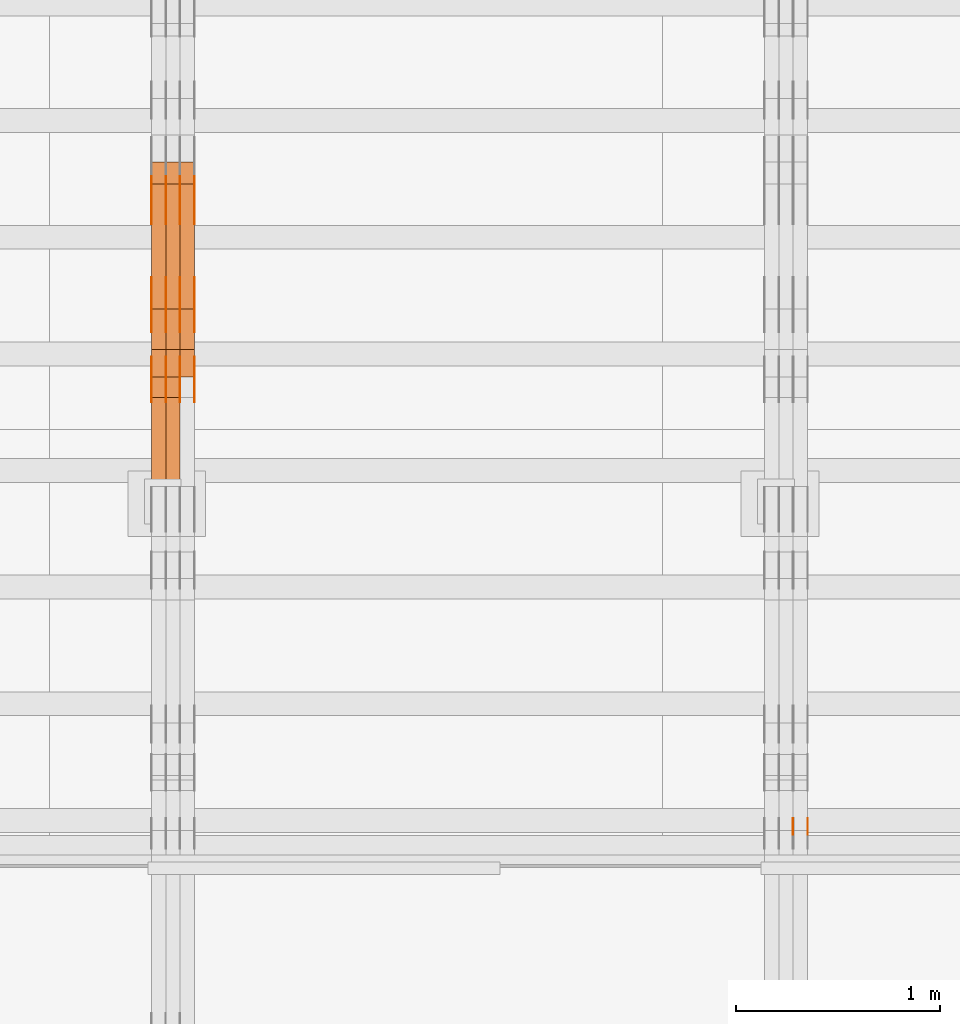
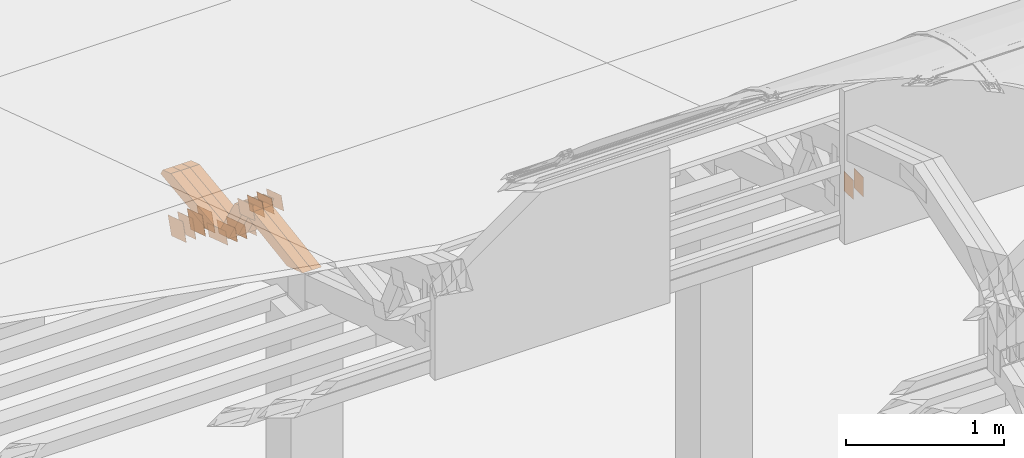
# One storey, part 149 of 385: 28 proxies.
"""IFC2X3 building model written with IfcOpenShell, lengths in millimetres."""

import ifcopenshell
import ifcopenshell.guid

model = None  # the IFC model being written
_history = None  # IfcOwnerHistory: only IFC2X3 demands one
_inside = {}  # id of a spatial element -> (the spatial element, [elements in it])
_under = {}  # id of a project, library or spatial element -> (it, [spatial elements below it])
_declared = {}  # id of a project -> (the project, [libraries it declares])
_typed = {}  # id of a type object -> (the type object, [elements of that type])
_made_of = {}  # id of a material, layer set ... -> (it, [elements and type objects made of it])


def new_model(schema):
    """Start an empty IFC model of exactly this schema.

    Asked for "IFC4X3", IfcOpenShell would pick the latest addendum, in which some entities
    have other attributes; the version numbers below select the first issue.
    IFC2X3 requires an IfcOwnerHistory on every rooted entity: one is made here for all.
    """
    global model, _history
    if schema == "IFC4X3":
        model = ifcopenshell.file(schema_version=(4, 3, 0, 0))
    else:
        model = ifcopenshell.file(schema=schema)
    _inside.clear()
    _under.clear()
    _declared.clear()
    _typed.clear()
    _made_of.clear()
    _history = None
    if model.schema == "IFC2X3":
        org = make("IfcOrganization", Name="unknown")
        user = make(
            "IfcPersonAndOrganization",
            ThePerson=make("IfcPerson", FamilyName="unknown"),
            TheOrganization=org,
        )
        app = make(
            "IfcApplication",
            ApplicationDeveloper=org,
            Version="unknown",
            ApplicationFullName="unknown",
            ApplicationIdentifier="unknown",
        )
        _history = make(
            "IfcOwnerHistory",
            OwningUser=user,
            OwningApplication=app,
            ChangeAction="ADDED",
            CreationDate=0,
        )
    return model


def make(cls, **values):
    """One entity of the class cls with the attributes given. An attribute that is None is left unset."""
    return model.create_entity(
        cls, **{name: value for name, value in values.items() if value is not None}
    )


def entity(cls, *values):
    """Any entity or typed value of the class cls, its attributes in the order of the schema. None: left unset."""
    e = model.create_entity(cls)
    for i, value in enumerate(values):
        if value is not None:
            e[i] = value
    return e


def rooted(cls, **values):
    """An entity with a GlobalId (a new one), such as an element, a storey or a relation."""
    return make(cls, GlobalId=ifcopenshell.guid.new(), OwnerHistory=_history, **values)


def si_unit(unit_type, name, prefix=None):
    """IfcSIUnit, for example si_unit("LENGTHUNIT", "METRE", prefix="MILLI")."""
    return make("IfcSIUnit", UnitType=unit_type, Prefix=prefix, Name=name)


def converted_unit(unit_type, name, factor, base, dimensions=None, offset=None):
    """IfcConversionBasedUnit, such as the inch: factor (a typed value) times the base unit."""
    return make(
        "IfcConversionBasedUnit"
        if offset is None
        else "IfcConversionBasedUnitWithOffset",
        ConversionOffset=offset,
        Dimensions=None
        if dimensions is None
        else entity("IfcDimensionalExponents", *dimensions),
        UnitType=unit_type,
        Name=name,
        ConversionFactor=make(
            "IfcMeasureWithUnit", ValueComponent=factor, UnitComponent=base
        ),
    )


def derived_unit(unit_type, elements):
    """IfcDerivedUnit: a product of units, each with its exponent."""
    return make(
        "IfcDerivedUnit",
        Elements=[
            make("IfcDerivedUnitElement", Unit=unit, Exponent=power)
            for unit, power in elements
        ],
        UnitType=unit_type,
    )


def assignment(units):
    """IfcUnitAssignment: the units of a project."""
    return None if units is None else make("IfcUnitAssignment", Units=units)


def point(xyz):
    """IfcCartesianPoint."""
    return None if xyz is None else make("IfcCartesianPoint", Coordinates=xyz)


def direction(xyz):
    """IfcDirection."""
    return None if xyz is None else make("IfcDirection", DirectionRatios=xyz)


def frame(location, z_axis=None, x_axis=None):
    """IfcAxis2Placement3D, a coordinate frame: its origin and axes. An axis left out is left unset."""
    return make(
        "IfcAxis2Placement3D",
        Location=point(location),
        Axis=direction(z_axis),
        RefDirection=direction(x_axis),
    )


def frame_2d(location, x_axis=None):
    """IfcAxis2Placement2D, a coordinate frame in the plane: its origin and x axis."""
    return make(
        "IfcAxis2Placement2D", Location=point(location), RefDirection=direction(x_axis)
    )


def origin():
    """The frame at (0, 0, 0) with its axes left unset."""
    return frame((0.0, 0.0, 0.0))


def origin_2d_with_axis():
    """The frame at (0, 0) in the plane with the x axis (1, 0) written out."""
    return frame_2d((0.0, 0.0), x_axis=(1.0, 0.0))


def place(relative_to, where):
    """IfcLocalPlacement: puts the frame where relative to a parent placement (None: the world)."""
    return make(
        "IfcLocalPlacement", PlacementRelTo=relative_to, RelativePlacement=where
    )


def context(
    kind, dimensions, precision=None, world=None, true_north=None, identifier=None
):
    """IfcGeometricRepresentationContext, for example the 3D "Model" context."""
    return make(
        "IfcGeometricRepresentationContext",
        ContextIdentifier=identifier,
        ContextType=kind,
        CoordinateSpaceDimension=dimensions,
        Precision=precision,
        WorldCoordinateSystem=world,
        TrueNorth=true_north,
    )


def subcontext(parent, identifier, kind, view, scale=None):
    """IfcGeometricRepresentationSubContext, for example "Body" below "Model"."""
    return make(
        "IfcGeometricRepresentationSubContext",
        ContextIdentifier=identifier,
        ContextType=kind,
        ParentContext=parent,
        TargetScale=scale,
        TargetView=view,
    )


def project(units=None, contexts=None):
    """IfcProject with its units and contexts."""
    return rooted(
        "IfcProject",
        Name="project",
        RepresentationContexts=contexts,
        UnitsInContext=assignment(units),
    )


def spatial(cls, under=None, at=None, **own):
    """A site, building, storey or space (cls), placed at a placement, below another one or the project."""
    s = rooted(cls, ObjectPlacement=at, **own)
    if under is not None:
        _under.setdefault(under.id(), (under, []))[1].append(s)
    return s


def polyline(points):
    """IfcPolyline through the points."""
    return make("IfcPolyline", Points=[point(p) for p in points])


def profile(cls, at=None, kind="AREA", **sizes):
    """A parametric profile (cls). Its sizes go by their IFC names, for example OverallWidth=200.0."""
    return make(cls, ProfileType=kind, Position=at, **sizes)


def rectangle(**sizes):
    """IfcRectangleProfileDef."""
    return profile("IfcRectangleProfileDef", **sizes)


def outline(outer, holes=None, kind="AREA"):
    """IfcArbitraryClosedProfileDef: a profile drawn as a closed curve; with holes, ...WithVoids."""
    if holes is None:
        return make("IfcArbitraryClosedProfileDef", ProfileType=kind, OuterCurve=outer)
    return make(
        "IfcArbitraryProfileDefWithVoids",
        ProfileType=kind,
        OuterCurve=outer,
        InnerCurves=holes,
    )


def extrude(swept, where, along, depth):
    """IfcExtrudedAreaSolid: the profile swept, set in the frame where, extruded along a direction by depth."""
    return make(
        "IfcExtrudedAreaSolid",
        SweptArea=swept,
        Position=where,
        ExtrudedDirection=direction(along),
        Depth=depth,
    )


def shape(context_of_items, identifier, shape_type, items):
    """IfcShapeRepresentation: the items that make up one representation, for example the "Body"."""
    return make(
        "IfcShapeRepresentation",
        ContextOfItems=context_of_items,
        RepresentationIdentifier=identifier,
        RepresentationType=shape_type,
        Items=items,
    )


def source(mapping_origin, context_of_items, identifier, shape_type, items):
    """IfcRepresentationMap: a shape defined once, which mapped items show again and again."""
    return make(
        "IfcRepresentationMap",
        MappingOrigin=mapping_origin,
        MappedRepresentation=shape(context_of_items, identifier, shape_type, items),
    )


def transform(
    local_origin,
    x_axis=None,
    y_axis=None,
    z_axis=None,
    scale=None,
    scale2=None,
    scale3=None,
    uniform=True,
):
    """IfcCartesianTransformationOperator3D, or its non-uniform kind. x_axis, y_axis, z_axis: its Axis1, 2, 3."""
    if uniform:
        return make(
            "IfcCartesianTransformationOperator3D",
            Axis1=direction(x_axis),
            Axis2=direction(y_axis),
            LocalOrigin=point(local_origin),
            Scale=scale,
            Axis3=direction(z_axis),
        )
    return make(
        "IfcCartesianTransformationOperator3DnonUniform",
        Axis1=direction(x_axis),
        Axis2=direction(y_axis),
        LocalOrigin=point(local_origin),
        Scale=scale,
        Axis3=direction(z_axis),
        Scale2=scale2,
        Scale3=scale3,
    )


def mapped(mapping_source, mapping_target):
    """IfcMappedItem: shows the shape of a source again, moved by a transform."""
    return make(
        "IfcMappedItem", MappingSource=mapping_source, MappingTarget=mapping_target
    )


def material(Name=None, Category=None):
    """IfcMaterial."""
    return make("IfcMaterial", Name=Name, Category=Category)


def made_of(thing, what):
    """Note that an element or type object is made of a material, layer set ...; save() writes the relation."""
    if what is not None:
        _made_of.setdefault(what.id(), (what, []))[1].append(thing)
    return thing


def type_object(cls, material=None, **own):
    """A type object (cls), such as IfcWallType, which elements share."""
    return made_of(rooted(cls, **own), material)


def type_shapes(of_type, sources):
    """Give a type object the sources (RepresentationMaps) that its elements show as mapped items."""
    of_type.RepresentationMaps = sources


def element(
    cls,
    number,
    at=None,
    inside=None,
    cuts=None,
    type_object=None,
    material=None,
    context=None,
    identifier="Body",
    shape_type=None,
    held_by="IfcProductDefinitionShape",
    body=None,
    shapes=None,
    **own,
):
    """One element of the class cls, such as IfcWall. Its Tag is "e" and its number.

    at: its placement. inside: the storey or other place that contains it. cuts: it is an
    opening in that element (IfcRelVoidsElement). A single representation is given by context,
    identifier, shape_type and body (its items); several are given by shapes. held_by: the class
    of the entity that holds the representations. save() writes the other relations.
    """
    e = rooted(cls, Tag="e%d" % number, ObjectPlacement=at, **own)
    if body is not None:
        shapes = [shape(context, identifier, shape_type, body)]
    if shapes is not None:
        e.Representation = make(held_by, Representations=shapes)
    if inside is not None:
        _inside.setdefault(inside.id(), (inside, []))[1].append(e)
    if cuts is not None:
        rooted(
            "IfcRelVoidsElement", RelatingBuildingElement=cuts, RelatedOpeningElement=e
        )
    if type_object is not None:
        _typed.setdefault(type_object.id(), (type_object, []))[1].append(e)
    return made_of(e, material)


def aggregate(whole, parts):
    """IfcRelAggregates: a whole, such as a stair, and the parts it consists of."""
    return rooted("IfcRelAggregates", RelatingObject=whole, RelatedObjects=parts)


def save(model, path):
    """Write the relations noted so far, then the file.

    IfcRelAggregates (storeys below a building ...), IfcRelContainedInSpatialStructure (elements
    in a storey), IfcRelDefinesByType, IfcRelAssociatesMaterial and IfcRelDeclares: one each for
    every whole, place, type object, material and project.
    """
    for whole, parts in _under.values():
        aggregate(whole, parts)
    for where, things in _inside.values():
        rooted(
            "IfcRelContainedInSpatialStructure",
            RelatedElements=things,
            RelatingStructure=where,
        )
    for kind, things in _typed.values():
        rooted("IfcRelDefinesByType", RelatedObjects=things, RelatingType=kind)
    for what, things in _made_of.values():
        rooted("IfcRelAssociatesMaterial", RelatedObjects=things, RelatingMaterial=what)
    for by, libraries in _declared.values():
        rooted("IfcRelDeclares", RelatingContext=by, RelatedDefinitions=libraries)
    model.write(path)


model = new_model("IFC2X3")

# Units and contexts
model_context = context("Model", 3, precision=0.01, world=origin(), true_north=direction((6.12303176911189e-17, 1.0)))
body_context = subcontext(model_context, "Body", "Model", "MODEL_VIEW")
ifc_project = project(units=[si_unit("LENGTHUNIT", "METRE", prefix="MILLI"), si_unit("AREAUNIT", "SQUARE_METRE"), si_unit("VOLUMEUNIT", "CUBIC_METRE"), converted_unit("PLANEANGLEUNIT", "DEGREE", entity("IfcRatioMeasure", 0.0174532925199433), si_unit("PLANEANGLEUNIT", "RADIAN"), dimensions=[0, 0, 0, 0, 0, 0, 0]), si_unit("MASSUNIT", "GRAM", prefix="KILO"), derived_unit("MASSDENSITYUNIT", [(si_unit("MASSUNIT", "GRAM", prefix="KILO"), 1), (si_unit("LENGTHUNIT", "METRE"), -3)]), si_unit("TIMEUNIT", "SECOND"), si_unit("FREQUENCYUNIT", "HERTZ"), si_unit("THERMODYNAMICTEMPERATUREUNIT", "DEGREE_CELSIUS"), derived_unit("THERMALTRANSMITTANCEUNIT", [(si_unit("MASSUNIT", "GRAM", prefix="KILO"), 1), (si_unit("THERMODYNAMICTEMPERATUREUNIT", "KELVIN"), -1), (si_unit("TIMEUNIT", "SECOND"), -3)]), derived_unit("VOLUMETRICFLOWRATEUNIT", [(si_unit("LENGTHUNIT", "METRE"), 3), (si_unit("TIMEUNIT", "SECOND"), -1)]), si_unit("ELECTRICCURRENTUNIT", "AMPERE"), si_unit("ELECTRICVOLTAGEUNIT", "VOLT"), si_unit("POWERUNIT", "WATT"), si_unit("FORCEUNIT", "NEWTON", prefix="KILO"), si_unit("ILLUMINANCEUNIT", "LUX"), si_unit("LUMINOUSFLUXUNIT", "LUMEN"), si_unit("LUMINOUSINTENSITYUNIT", "CANDELA"), derived_unit("USERDEFINED", [(si_unit("MASSUNIT", "GRAM", prefix="KILO"), -1), (si_unit("LENGTHUNIT", "METRE"), -2), (si_unit("TIMEUNIT", "SECOND"), 3), (si_unit("LUMINOUSFLUXUNIT", "LUMEN"), 1)]), derived_unit("LINEARVELOCITYUNIT", [(si_unit("LENGTHUNIT", "METRE"), 1), (si_unit("TIMEUNIT", "SECOND"), -1)]), si_unit("PRESSUREUNIT", "PASCAL"), derived_unit("USERDEFINED", [(si_unit("LENGTHUNIT", "METRE"), -2), (si_unit("MASSUNIT", "GRAM", prefix="KILO"), 1), (si_unit("TIMEUNIT", "SECOND"), -2)])], contexts=[model_context])

# Site, building, storey
site_placement = place(None, origin())
site = spatial("IfcSite", under=ifc_project, at=site_placement, CompositionType="ELEMENT")
building_placement = place(site_placement, origin())
building = spatial("IfcBuilding", under=site, at=building_placement, CompositionType="ELEMENT")
storey_placement = place(building_placement, origin())
storey = spatial("IfcBuildingStorey", under=building, at=storey_placement, Name="Default", CompositionType="ELEMENT", Elevation=0.0)

# Proxies
ifc_material_1 = material(Name="IfcSurfaceStyle #274242")
building_element_proxy_type_1 = type_object("IfcBuildingElementProxyType", PredefinedType="NOTDEFINED", material=ifc_material_1)
shared_shape_1 = source(origin(), body_context, "Body", "SweptSolid", [
    extrude(rectangle(XDim=150.0, YDim=120.0, at=origin_2d_with_axis()), frame((75.0, 60.0, 0.0), z_axis=(0.0, 0.0, 1.0), x_axis=(-1.0, 0.0, 0.0)), (0.0, 0.0, 1.0), 1.3),
])
type_shapes(building_element_proxy_type_1, [shared_shape_1])
proxy_1_placement = place(building_placement, frame((21386.3, 15840.0, 3652.70166015625), z_axis=(-1.0, 0.0, 0.0), x_axis=(0.0, 0.0, -1.0)))
element("IfcBuildingElementProxy", 1, at=proxy_1_placement, inside=storey, type_object=building_element_proxy_type_1, material=ifc_material_1, context=body_context, shape_type="MappedRepresentation", body=[
    mapped(shared_shape_1, transform((0.0, 0.0, 0.0), scale=1.0)),
])
ifc_material_2 = material(Name="IfcSurfaceStyle #274185")
building_element_proxy_type_2 = type_object("IfcBuildingElementProxyType", PredefinedType="NOTDEFINED", material=ifc_material_2)
shared_shape_2 = source(origin(), body_context, "Body", "SweptSolid", [
    extrude(rectangle(XDim=150.0, YDim=120.0, at=origin_2d_with_axis()), frame((75.0, 60.0, 0.0), z_axis=(0.0, 0.0, 1.0), x_axis=(-1.0, 0.0, 0.0)), (0.0, 0.0, 1.0), 1.3),
])
type_shapes(building_element_proxy_type_2, [shared_shape_2])
proxy_2_placement = place(building_placement, frame((21315.0, 15840.0, 3652.70166015625), z_axis=(-1.0, 0.0, 0.0), x_axis=(0.0, 0.0, -1.0)))
element("IfcBuildingElementProxy", 2, at=proxy_2_placement, inside=storey, type_object=building_element_proxy_type_2, material=ifc_material_2, context=body_context, shape_type="MappedRepresentation", body=[
    mapped(shared_shape_2, transform((0.0, 0.0, 0.0), scale=1.0)),
])
ifc_material_3 = material(Name="IfcSurfaceStyle #239126")
building_element_proxy_type_3 = type_object("IfcBuildingElementProxyType", PredefinedType="NOTDEFINED", material=ifc_material_3)
shared_shape_3 = source(origin(), body_context, "Body", "SweptSolid", [
    extrude(outline(polyline([(-125.00031378339, -47.9999612158856), (125.000225258022, -47.9999612158856), (124.999811678525, 47.9999612158856), (-124.999723153156, 47.9999612158856), (-125.00031378339, -47.9999612158856)])), frame((125.000225258022, 48.0000091013474, 0.0), z_axis=(0.0, 0.0, 1.0), x_axis=(-1.0, 0.0, 0.0)), (0.0, 0.0, 1.0), 1.3),
])
type_shapes(building_element_proxy_type_3, [shared_shape_3])
proxy_3_placement = place(building_placement, frame((18386.3, 18456.8597683375, 2657.46691321253), z_axis=(-1.0, 0.0, 0.0), x_axis=(0.0, -0.951056516295124, 0.309016994375039)))
element("IfcBuildingElementProxy", 3, at=proxy_3_placement, inside=storey, type_object=building_element_proxy_type_3, material=ifc_material_3, context=body_context, shape_type="MappedRepresentation", body=[
    mapped(shared_shape_3, transform((0.0, 0.0, 0.0), scale=1.0)),
])
ifc_material_4 = material(Name="IfcSurfaceStyle #239069")
building_element_proxy_type_4 = type_object("IfcBuildingElementProxyType", PredefinedType="NOTDEFINED", material=ifc_material_4)
shared_shape_4 = source(origin(), body_context, "Body", "SweptSolid", [
    extrude(outline(polyline([(-125.00031378339, -47.9999612158856), (125.000225258022, -47.9999612158856), (124.999811678525, 47.9999612158856), (-124.999723153156, 47.9999612158856), (-125.00031378339, -47.9999612158856)])), frame((125.000225258022, 48.0000091013474, 0.0), z_axis=(0.0, 0.0, 1.0), x_axis=(-1.0, 0.0, 0.0)), (0.0, 0.0, 1.0), 1.3),
])
type_shapes(building_element_proxy_type_4, [shared_shape_4])
proxy_4_placement = place(building_placement, frame((18315.0, 18456.8597683375, 2657.46691321253), z_axis=(-1.0, 0.0, 0.0), x_axis=(0.0, -0.951056516295124, 0.309016994375039)))
element("IfcBuildingElementProxy", 4, at=proxy_4_placement, inside=storey, type_object=building_element_proxy_type_4, material=ifc_material_4, context=body_context, shape_type="MappedRepresentation", body=[
    mapped(shared_shape_4, transform((0.0, 0.0, 0.0), scale=1.0)),
])
ifc_material_5 = material(Name="IfcSurfaceStyle #239012")
building_element_proxy_type_5 = type_object("IfcBuildingElementProxyType", PredefinedType="NOTDEFINED", material=ifc_material_5)
shared_shape_5 = source(origin(), body_context, "Body", "SweptSolid", [
    extrude(outline(polyline([(-125.00031378339, -47.9999612158856), (125.000225258022, -47.9999612158856), (124.999811678525, 47.9999612158856), (-124.999723153156, 47.9999612158856), (-125.00031378339, -47.9999612158856)])), frame((125.000225258022, 48.0000091013474, 0.0), z_axis=(0.0, 0.0, 1.0), x_axis=(-1.0, 0.0, 0.0)), (0.0, 0.0, 1.0), 1.3),
])
type_shapes(building_element_proxy_type_5, [shared_shape_5])
proxy_5_placement = place(building_placement, frame((18316.3, 18456.8597683375, 2657.46691321253), z_axis=(-1.0, 0.0, 0.0), x_axis=(0.0, -0.951056516295124, 0.309016994375039)))
element("IfcBuildingElementProxy", 5, at=proxy_5_placement, inside=storey, type_object=building_element_proxy_type_5, material=ifc_material_5, context=body_context, shape_type="MappedRepresentation", body=[
    mapped(shared_shape_5, transform((0.0, 0.0, 0.0), scale=1.0)),
])
ifc_material_6 = material(Name="IfcSurfaceStyle #238955")
building_element_proxy_type_6 = type_object("IfcBuildingElementProxyType", PredefinedType="NOTDEFINED", material=ifc_material_6)
shared_shape_6 = source(origin(), body_context, "Body", "SweptSolid", [
    extrude(outline(polyline([(-125.00031378339, -47.9999612158856), (125.000225258022, -47.9999612158856), (124.999811678525, 47.9999612158856), (-124.999723153156, 47.9999612158856), (-125.00031378339, -47.9999612158856)])), frame((125.000225258022, 48.0000091013474, 0.0), z_axis=(0.0, 0.0, 1.0), x_axis=(-1.0, 0.0, 0.0)), (0.0, 0.0, 1.0), 1.29999999999998),
])
type_shapes(building_element_proxy_type_6, [shared_shape_6])
proxy_6_placement = place(building_placement, frame((18245.0, 18456.8597683375, 2657.46691321253), z_axis=(-1.0, 0.0, 0.0), x_axis=(0.0, -0.951056516295124, 0.309016994375039)))
element("IfcBuildingElementProxy", 6, at=proxy_6_placement, inside=storey, type_object=building_element_proxy_type_6, material=ifc_material_6, context=body_context, shape_type="MappedRepresentation", body=[
    mapped(shared_shape_6, transform((0.0, 0.0, 0.0), scale=1.0)),
])
ifc_material_7 = material(Name="IfcSurfaceStyle #238898")
building_element_proxy_type_7 = type_object("IfcBuildingElementProxyType", PredefinedType="NOTDEFINED", material=ifc_material_7)
shared_shape_7 = source(origin(), body_context, "Body", "SweptSolid", [
    extrude(outline(polyline([(-125.00031378339, -47.9999612158856), (125.000225258022, -47.9999612158856), (124.999811678525, 47.9999612158856), (-124.999723153156, 47.9999612158856), (-125.00031378339, -47.9999612158856)])), frame((125.000225258022, 48.0000091013474, 0.0), z_axis=(0.0, 0.0, 1.0), x_axis=(-1.0, 0.0, 0.0)), (0.0, 0.0, 1.0), 1.29999999999998),
])
type_shapes(building_element_proxy_type_7, [shared_shape_7])
proxy_7_placement = place(building_placement, frame((18246.3, 18456.8597683375, 2657.46691321253), z_axis=(-1.0, 0.0, 0.0), x_axis=(0.0, -0.951056516295124, 0.309016994375039)))
element("IfcBuildingElementProxy", 7, at=proxy_7_placement, inside=storey, type_object=building_element_proxy_type_7, material=ifc_material_7, context=body_context, shape_type="MappedRepresentation", body=[
    mapped(shared_shape_7, transform((0.0, 0.0, 0.0), scale=1.0)),
])
ifc_material_8 = material(Name="IfcSurfaceStyle #238841")
building_element_proxy_type_8 = type_object("IfcBuildingElementProxyType", PredefinedType="NOTDEFINED", material=ifc_material_8)
shared_shape_8 = source(origin(), body_context, "Body", "SweptSolid", [
    extrude(outline(polyline([(-125.00031378339, -47.9999612158856), (125.000225258022, -47.9999612158856), (124.999811678525, 47.9999612158856), (-124.999723153156, 47.9999612158856), (-125.00031378339, -47.9999612158856)])), frame((125.000225258022, 48.0000091013474, 0.0), z_axis=(0.0, 0.0, 1.0), x_axis=(-1.0, 0.0, 0.0)), (0.0, 0.0, 1.0), 1.29999999999998),
])
type_shapes(building_element_proxy_type_8, [shared_shape_8])
proxy_8_placement = place(building_placement, frame((18175.0, 18456.8597683375, 2657.46691321253), z_axis=(-1.0, 0.0, 0.0), x_axis=(0.0, -0.951056516295124, 0.309016994375039)))
element("IfcBuildingElementProxy", 8, at=proxy_8_placement, inside=storey, type_object=building_element_proxy_type_8, material=ifc_material_8, context=body_context, shape_type="MappedRepresentation", body=[
    mapped(shared_shape_8, transform((0.0, 0.0, 0.0), scale=1.0)),
])
ifc_material_9 = material(Name="IfcSurfaceStyle #237416")
building_element_proxy_type_9 = type_object("IfcBuildingElementProxyType", PredefinedType="NOTDEFINED", material=ifc_material_9)
shared_shape_9 = source(origin(), body_context, "Body", "SweptSolid", [
    extrude(outline(polyline([(-99.999796294464, -72.0000050220467), (99.9998768370438, -72.0000050220467), (100.000260677528, 72.0000050220467), (-100.000341220108, 72.0000050220467), (-99.999796294464, -72.0000050220467)])), frame((100.000260677528, 72.0000050220467, 0.0), z_axis=(0.0, 0.0, 1.0), x_axis=(-1.0, 0.0, 0.0)), (0.0, 0.0, 1.0), 1.3),
])
type_shapes(building_element_proxy_type_9, [shared_shape_9])
proxy_9_placement = place(building_placement, frame((18386.3, 18936.3876569477, 2373.90613192527), z_axis=(-1.0, 0.0, 0.0), x_axis=(0.0, -0.951056516295124, 0.309016994375039)))
element("IfcBuildingElementProxy", 9, at=proxy_9_placement, inside=storey, type_object=building_element_proxy_type_9, material=ifc_material_9, context=body_context, shape_type="MappedRepresentation", body=[
    mapped(shared_shape_9, transform((0.0, 0.0, 0.0), scale=1.0)),
])
ifc_material_10 = material(Name="IfcSurfaceStyle #237359")
building_element_proxy_type_10 = type_object("IfcBuildingElementProxyType", PredefinedType="NOTDEFINED", material=ifc_material_10)
shared_shape_10 = source(origin(), body_context, "Body", "SweptSolid", [
    extrude(outline(polyline([(-99.999796294464, -72.0000050220467), (99.9998768370438, -72.0000050220467), (100.000260677528, 72.0000050220467), (-100.000341220108, 72.0000050220467), (-99.999796294464, -72.0000050220467)])), frame((100.000260677528, 72.0000050220467, 0.0), z_axis=(0.0, 0.0, 1.0), x_axis=(-1.0, 0.0, 0.0)), (0.0, 0.0, 1.0), 1.3),
])
type_shapes(building_element_proxy_type_10, [shared_shape_10])
proxy_10_placement = place(building_placement, frame((18315.0, 18936.3876569477, 2373.90613192527), z_axis=(-1.0, 0.0, 0.0), x_axis=(0.0, -0.951056516295124, 0.309016994375039)))
element("IfcBuildingElementProxy", 10, at=proxy_10_placement, inside=storey, type_object=building_element_proxy_type_10, material=ifc_material_10, context=body_context, shape_type="MappedRepresentation", body=[
    mapped(shared_shape_10, transform((0.0, 0.0, 0.0), scale=1.0)),
])
ifc_material_11 = material(Name="IfcSurfaceStyle #237302")
building_element_proxy_type_11 = type_object("IfcBuildingElementProxyType", PredefinedType="NOTDEFINED", material=ifc_material_11)
shared_shape_11 = source(origin(), body_context, "Body", "SweptSolid", [
    extrude(outline(polyline([(-99.999796294464, -72.0000050220467), (99.9998768370438, -72.0000050220467), (100.000260677528, 72.0000050220467), (-100.000341220108, 72.0000050220467), (-99.999796294464, -72.0000050220467)])), frame((100.000260677528, 72.0000050220467, 0.0), z_axis=(0.0, 0.0, 1.0), x_axis=(-1.0, 0.0, 0.0)), (0.0, 0.0, 1.0), 1.3),
])
type_shapes(building_element_proxy_type_11, [shared_shape_11])
proxy_11_placement = place(building_placement, frame((18316.3, 18936.3876569477, 2373.90613192527), z_axis=(-1.0, 0.0, 0.0), x_axis=(0.0, -0.951056516295124, 0.309016994375039)))
element("IfcBuildingElementProxy", 11, at=proxy_11_placement, inside=storey, type_object=building_element_proxy_type_11, material=ifc_material_11, context=body_context, shape_type="MappedRepresentation", body=[
    mapped(shared_shape_11, transform((0.0, 0.0, 0.0), scale=1.0)),
])
ifc_material_12 = material(Name="IfcSurfaceStyle #237245")
building_element_proxy_type_12 = type_object("IfcBuildingElementProxyType", PredefinedType="NOTDEFINED", material=ifc_material_12)
shared_shape_12 = source(origin(), body_context, "Body", "SweptSolid", [
    extrude(outline(polyline([(-99.999796294464, -72.0000050220467), (99.9998768370438, -72.0000050220467), (100.000260677528, 72.0000050220467), (-100.000341220108, 72.0000050220467), (-99.999796294464, -72.0000050220467)])), frame((100.000260677528, 72.0000050220467, 0.0), z_axis=(0.0, 0.0, 1.0), x_axis=(-1.0, 0.0, 0.0)), (0.0, 0.0, 1.0), 1.29999999999998),
])
type_shapes(building_element_proxy_type_12, [shared_shape_12])
proxy_12_placement = place(building_placement, frame((18245.0, 18936.3876569477, 2373.90613192527), z_axis=(-1.0, 0.0, 0.0), x_axis=(0.0, -0.951056516295124, 0.309016994375039)))
element("IfcBuildingElementProxy", 12, at=proxy_12_placement, inside=storey, type_object=building_element_proxy_type_12, material=ifc_material_12, context=body_context, shape_type="MappedRepresentation", body=[
    mapped(shared_shape_12, transform((0.0, 0.0, 0.0), scale=1.0)),
])
ifc_material_13 = material(Name="IfcSurfaceStyle #237188")
building_element_proxy_type_13 = type_object("IfcBuildingElementProxyType", PredefinedType="NOTDEFINED", material=ifc_material_13)
shared_shape_13 = source(origin(), body_context, "Body", "SweptSolid", [
    extrude(outline(polyline([(-99.999796294464, -72.0000050220467), (99.9998768370438, -72.0000050220467), (100.000260677528, 72.0000050220467), (-100.000341220108, 72.0000050220467), (-99.999796294464, -72.0000050220467)])), frame((100.000260677528, 72.0000050220467, 0.0), z_axis=(0.0, 0.0, 1.0), x_axis=(-1.0, 0.0, 0.0)), (0.0, 0.0, 1.0), 1.29999999999998),
])
type_shapes(building_element_proxy_type_13, [shared_shape_13])
proxy_13_placement = place(building_placement, frame((18246.3, 18936.3876569477, 2373.90613192527), z_axis=(-1.0, 0.0, 0.0), x_axis=(0.0, -0.951056516295124, 0.309016994375039)))
element("IfcBuildingElementProxy", 13, at=proxy_13_placement, inside=storey, type_object=building_element_proxy_type_13, material=ifc_material_13, context=body_context, shape_type="MappedRepresentation", body=[
    mapped(shared_shape_13, transform((0.0, 0.0, 0.0), scale=1.0)),
])
ifc_material_14 = material(Name="IfcSurfaceStyle #237131")
building_element_proxy_type_14 = type_object("IfcBuildingElementProxyType", PredefinedType="NOTDEFINED", material=ifc_material_14)
shared_shape_14 = source(origin(), body_context, "Body", "SweptSolid", [
    extrude(outline(polyline([(-99.999796294464, -72.0000050220467), (99.9998768370438, -72.0000050220467), (100.000260677528, 72.0000050220467), (-100.000341220108, 72.0000050220467), (-99.999796294464, -72.0000050220467)])), frame((100.000260677528, 72.0000050220467, 0.0), z_axis=(0.0, 0.0, 1.0), x_axis=(-1.0, 0.0, 0.0)), (0.0, 0.0, 1.0), 1.29999999999999),
])
type_shapes(building_element_proxy_type_14, [shared_shape_14])
proxy_14_placement = place(building_placement, frame((18175.0, 18936.3876569477, 2373.90613192527), z_axis=(-1.0, 0.0, 0.0), x_axis=(0.0, -0.951056516295124, 0.309016994375039)))
element("IfcBuildingElementProxy", 14, at=proxy_14_placement, inside=storey, type_object=building_element_proxy_type_14, material=ifc_material_14, context=body_context, shape_type="MappedRepresentation", body=[
    mapped(shared_shape_14, transform((0.0, 0.0, 0.0), scale=1.0)),
])
ifc_material_15 = material(Name="IfcSurfaceStyle #232970")
building_element_proxy_type_15 = type_object("IfcBuildingElementProxyType", PredefinedType="NOTDEFINED", material=ifc_material_15)
shared_shape_15 = source(origin(), body_context, "Body", "SweptSolid", [
    extrude(outline(polyline([(-99.9999427841299, -54.0000599375792), (99.9996549037756, -54.0000599375792), (100.000407167194, 54.0000599375792), (-100.00011928684, 54.0000599375792), (-99.9999427841299, -54.0000599375792)])), frame((100.000407167194, 54.0000599375792, 0.0), z_axis=(0.0, 0.0, 1.0), x_axis=(-1.0, 0.0, 0.0)), (0.0, 0.0, 1.0), 1.3),
])
type_shapes(building_element_proxy_type_15, [shared_shape_15])
proxy_15_placement = place(building_placement, frame((18386.3, 18065.0682492591, 3072.55239547302), z_axis=(-1.0, 0.0, 0.0), x_axis=(0.0, -0.951056516295154, 0.309016994374948)))
element("IfcBuildingElementProxy", 15, at=proxy_15_placement, inside=storey, type_object=building_element_proxy_type_15, material=ifc_material_15, context=body_context, shape_type="MappedRepresentation", body=[
    mapped(shared_shape_15, transform((0.0, 0.0, 0.0), scale=1.0)),
])
ifc_material_16 = material(Name="IfcSurfaceStyle #232913")
building_element_proxy_type_16 = type_object("IfcBuildingElementProxyType", PredefinedType="NOTDEFINED", material=ifc_material_16)
shared_shape_16 = source(origin(), body_context, "Body", "SweptSolid", [
    extrude(outline(polyline([(-99.9999427841299, -54.0000599375792), (99.9996549037756, -54.0000599375792), (100.000407167194, 54.0000599375792), (-100.00011928684, 54.0000599375792), (-99.9999427841299, -54.0000599375792)])), frame((100.000407167194, 54.0000599375792, 0.0), z_axis=(0.0, 0.0, 1.0), x_axis=(-1.0, 0.0, 0.0)), (0.0, 0.0, 1.0), 1.3),
])
type_shapes(building_element_proxy_type_16, [shared_shape_16])
proxy_16_placement = place(building_placement, frame((18315.0, 18065.0682492591, 3072.55239547302), z_axis=(-1.0, 0.0, 0.0), x_axis=(0.0, -0.951056516295154, 0.309016994374948)))
element("IfcBuildingElementProxy", 16, at=proxy_16_placement, inside=storey, type_object=building_element_proxy_type_16, material=ifc_material_16, context=body_context, shape_type="MappedRepresentation", body=[
    mapped(shared_shape_16, transform((0.0, 0.0, 0.0), scale=1.0)),
])
ifc_material_17 = material(Name="IfcSurfaceStyle #232856")
building_element_proxy_type_17 = type_object("IfcBuildingElementProxyType", PredefinedType="NOTDEFINED", material=ifc_material_17)
shared_shape_17 = source(origin(), body_context, "Body", "SweptSolid", [
    extrude(outline(polyline([(-99.9999427841299, -54.0000599375792), (99.9996549037756, -54.0000599375792), (100.000407167194, 54.0000599375792), (-100.00011928684, 54.0000599375792), (-99.9999427841299, -54.0000599375792)])), frame((100.000407167194, 54.0000599375792, 0.0), z_axis=(0.0, 0.0, 1.0), x_axis=(-1.0, 0.0, 0.0)), (0.0, 0.0, 1.0), 1.3),
])
type_shapes(building_element_proxy_type_17, [shared_shape_17])
proxy_17_placement = place(building_placement, frame((18316.3, 18065.0682492591, 3072.55239547302), z_axis=(-1.0, 0.0, 0.0), x_axis=(0.0, -0.951056516295154, 0.309016994374948)))
element("IfcBuildingElementProxy", 17, at=proxy_17_placement, inside=storey, type_object=building_element_proxy_type_17, material=ifc_material_17, context=body_context, shape_type="MappedRepresentation", body=[
    mapped(shared_shape_17, transform((0.0, 0.0, 0.0), scale=1.0)),
])
ifc_material_18 = material(Name="IfcSurfaceStyle #232799")
building_element_proxy_type_18 = type_object("IfcBuildingElementProxyType", PredefinedType="NOTDEFINED", material=ifc_material_18)
shared_shape_18 = source(origin(), body_context, "Body", "SweptSolid", [
    extrude(outline(polyline([(-99.9999427841299, -54.0000599375792), (99.9996549037756, -54.0000599375792), (100.000407167194, 54.0000599375792), (-100.00011928684, 54.0000599375792), (-99.9999427841299, -54.0000599375792)])), frame((100.000407167194, 54.0000599375792, 0.0), z_axis=(0.0, 0.0, 1.0), x_axis=(-1.0, 0.0, 0.0)), (0.0, 0.0, 1.0), 1.29999999999998),
])
type_shapes(building_element_proxy_type_18, [shared_shape_18])
proxy_18_placement = place(building_placement, frame((18245.0, 18065.0682492591, 3072.55239547302), z_axis=(-1.0, 0.0, 0.0), x_axis=(0.0, -0.951056516295154, 0.309016994374948)))
element("IfcBuildingElementProxy", 18, at=proxy_18_placement, inside=storey, type_object=building_element_proxy_type_18, material=ifc_material_18, context=body_context, shape_type="MappedRepresentation", body=[
    mapped(shared_shape_18, transform((0.0, 0.0, 0.0), scale=1.0)),
])
ifc_material_19 = material(Name="IfcSurfaceStyle #232742")
building_element_proxy_type_19 = type_object("IfcBuildingElementProxyType", PredefinedType="NOTDEFINED", material=ifc_material_19)
shared_shape_19 = source(origin(), body_context, "Body", "SweptSolid", [
    extrude(outline(polyline([(-99.9999427841299, -54.0000599375792), (99.9996549037756, -54.0000599375792), (100.000407167194, 54.0000599375792), (-100.00011928684, 54.0000599375792), (-99.9999427841299, -54.0000599375792)])), frame((100.000407167194, 54.0000599375792, 0.0), z_axis=(0.0, 0.0, 1.0), x_axis=(-1.0, 0.0, 0.0)), (0.0, 0.0, 1.0), 1.29999999999998),
])
type_shapes(building_element_proxy_type_19, [shared_shape_19])
proxy_19_placement = place(building_placement, frame((18246.3, 18065.0682492591, 3072.55239547302), z_axis=(-1.0, 0.0, 0.0), x_axis=(0.0, -0.951056516295154, 0.309016994374948)))
element("IfcBuildingElementProxy", 19, at=proxy_19_placement, inside=storey, type_object=building_element_proxy_type_19, material=ifc_material_19, context=body_context, shape_type="MappedRepresentation", body=[
    mapped(shared_shape_19, transform((0.0, 0.0, 0.0), scale=1.0)),
])
ifc_material_20 = material(Name="IfcSurfaceStyle #232685")
building_element_proxy_type_20 = type_object("IfcBuildingElementProxyType", PredefinedType="NOTDEFINED", material=ifc_material_20)
shared_shape_20 = source(origin(), body_context, "Body", "SweptSolid", [
    extrude(outline(polyline([(-99.9999427841299, -54.0000599375792), (99.9996549037756, -54.0000599375792), (100.000407167194, 54.0000599375792), (-100.00011928684, 54.0000599375792), (-99.9999427841299, -54.0000599375792)])), frame((100.000407167194, 54.0000599375792, 0.0), z_axis=(0.0, 0.0, 1.0), x_axis=(-1.0, 0.0, 0.0)), (0.0, 0.0, 1.0), 1.29999999999999),
])
type_shapes(building_element_proxy_type_20, [shared_shape_20])
proxy_20_placement = place(building_placement, frame((18175.0, 18065.0682492591, 3072.55239547302), z_axis=(-1.0, 0.0, 0.0), x_axis=(0.0, -0.951056516295154, 0.309016994374948)))
element("IfcBuildingElementProxy", 20, at=proxy_20_placement, inside=storey, type_object=building_element_proxy_type_20, material=ifc_material_20, context=body_context, shape_type="MappedRepresentation", body=[
    mapped(shared_shape_20, transform((0.0, 0.0, 0.0), scale=1.0)),
])
ifc_material_21 = material(Name="IfcSurfaceStyle #223148")
building_element_proxy_type_21 = type_object("IfcBuildingElementProxyType", Name="T1-W10 223146", PredefinedType="NOTDEFINED", material=ifc_material_21)
shared_shape_21 = source(origin(), body_context, "Body", "SweptSolid", [
    extrude(outline(polyline([(-459.546036710757, -47.5000436364511), (174.689450869018, -47.5000436364511), (268.831081103959, 0.00011114562912502), (287.286350706789, 47.4999880636365), (-271.260845969009, 47.4999880636366), (-459.546036710757, -47.5000436364511)])), frame((287.286768781132, 47.5001637448091, 0.0), z_axis=(0.0, 0.0, 1.0), x_axis=(-1.0, 0.0, 0.0)), (0.0, 0.0, 1.0), 70.0),
])
type_shapes(building_element_proxy_type_21, [shared_shape_21])
proxy_21_placement = place(building_placement, frame((18315.0, 18025.1410649788, 3112.76453857986), z_axis=(-1.0, 0.0, 0.0), x_axis=(0.0, -0.988299196256916, -0.152527698068035)))
element("IfcBuildingElementProxy", 21, at=proxy_21_placement, inside=storey, type_object=building_element_proxy_type_21, material=ifc_material_21, Name="T1-W10", context=body_context, shape_type="MappedRepresentation", body=[
    mapped(shared_shape_21, transform((0.0, 0.0, 0.0), scale=1.0)),
])
ifc_material_22 = material(Name="IfcSurfaceStyle #223082")
building_element_proxy_type_22 = type_object("IfcBuildingElementProxyType", Name="T1-W10 223080", PredefinedType="NOTDEFINED", material=ifc_material_22)
shared_shape_22 = source(origin(), body_context, "Body", "SweptSolid", [
    extrude(outline(polyline([(-459.546036710757, -47.5000436364511), (174.689450869018, -47.5000436364511), (268.831081103959, 0.00011114562912502), (287.286350706789, 47.4999880636365), (-271.260845969009, 47.4999880636366), (-459.546036710757, -47.5000436364511)])), frame((287.286768781132, 47.5001637448091, 0.0), z_axis=(0.0, 0.0, 1.0), x_axis=(-1.0, 0.0, 0.0)), (0.0, 0.0, 1.0), 70.0),
])
type_shapes(building_element_proxy_type_22, [shared_shape_22])
proxy_22_placement = place(building_placement, frame((18245.0, 18025.1410649788, 3112.76453857986), z_axis=(-1.0, 0.0, 0.0), x_axis=(0.0, -0.988299196256916, -0.152527698068035)))
element("IfcBuildingElementProxy", 22, at=proxy_22_placement, inside=storey, type_object=building_element_proxy_type_22, material=ifc_material_22, Name="T1-W10", context=body_context, shape_type="MappedRepresentation", body=[
    mapped(shared_shape_22, transform((0.0, 0.0, 0.0), scale=1.0)),
])
ifc_material_23 = material(Name="IfcSurfaceStyle #222818")
building_element_proxy_type_23 = type_object("IfcBuildingElementProxyType", Name="T1-W35 222816", PredefinedType="NOTDEFINED", material=ifc_material_23)
shared_shape_23 = source(origin(), body_context, "Body", "SweptSolid", [
    extrude(outline(polyline([(-196.877231354918, -47.499850828051), (197.289756738813, -47.499850828051), (177.380838136073, -0.000131002767018074), (124.615181369032, 47.4999163294346), (-302.408544889, 47.4999163294346), (-196.877231354918, -47.499850828051)])), frame((197.289756738813, 47.5002438363521, 0.0), z_axis=(0.0, 0.0, 1.0), x_axis=(-1.0, 0.0, 0.0)), (0.0, 0.0, 1.0), 70.0),
])
type_shapes(building_element_proxy_type_23, [shared_shape_23])
proxy_23_placement = place(building_placement, frame((18385.0, 18249.5528960018, 2724.16980022534), z_axis=(-1.0, 0.0, 0.0), x_axis=(0.0, -0.5, 0.866025403784439)))
element("IfcBuildingElementProxy", 23, at=proxy_23_placement, inside=storey, type_object=building_element_proxy_type_23, material=ifc_material_23, Name="T1-W35", context=body_context, shape_type="MappedRepresentation", body=[
    mapped(shared_shape_23, transform((0.0, 0.0, 0.0), scale=1.0)),
])
ifc_material_24 = material(Name="IfcSurfaceStyle #222752")
building_element_proxy_type_24 = type_object("IfcBuildingElementProxyType", Name="T1-W35 222750", PredefinedType="NOTDEFINED", material=ifc_material_24)
shared_shape_24 = source(origin(), body_context, "Body", "SweptSolid", [
    extrude(outline(polyline([(-196.877231354918, -47.499850828051), (197.289756738813, -47.499850828051), (177.380838136073, -0.000131002767018074), (124.615181369032, 47.4999163294346), (-302.408544889, 47.4999163294346), (-196.877231354918, -47.499850828051)])), frame((197.289756738813, 47.5002438363521, 0.0), z_axis=(0.0, 0.0, 1.0), x_axis=(-1.0, 0.0, 0.0)), (0.0, 0.0, 1.0), 70.0),
])
type_shapes(building_element_proxy_type_24, [shared_shape_24])
proxy_24_placement = place(building_placement, frame((18315.0, 18249.5528960018, 2724.16980022534), z_axis=(-1.0, 0.0, 0.0), x_axis=(0.0, -0.5, 0.866025403784439)))
element("IfcBuildingElementProxy", 24, at=proxy_24_placement, inside=storey, type_object=building_element_proxy_type_24, material=ifc_material_24, Name="T1-W35", context=body_context, shape_type="MappedRepresentation", body=[
    mapped(shared_shape_24, transform((0.0, 0.0, 0.0), scale=1.0)),
])
ifc_material_25 = material(Name="IfcSurfaceStyle #222686")
building_element_proxy_type_25 = type_object("IfcBuildingElementProxyType", Name="T1-W35 222684", PredefinedType="NOTDEFINED", material=ifc_material_25)
shared_shape_25 = source(origin(), body_context, "Body", "SweptSolid", [
    extrude(outline(polyline([(-196.877231354918, -47.499850828051), (197.289756738813, -47.499850828051), (177.380838136073, -0.000131002767018074), (124.615181369032, 47.4999163294346), (-302.408544889, 47.4999163294346), (-196.877231354918, -47.499850828051)])), frame((197.289756738813, 47.5002438363521, 0.0), z_axis=(0.0, 0.0, 1.0), x_axis=(-1.0, 0.0, 0.0)), (0.0, 0.0, 1.0), 70.0),
])
type_shapes(building_element_proxy_type_25, [shared_shape_25])
proxy_25_placement = place(building_placement, frame((18245.0, 18249.5528960018, 2724.16980022534), z_axis=(-1.0, 0.0, 0.0), x_axis=(0.0, -0.5, 0.866025403784439)))
element("IfcBuildingElementProxy", 25, at=proxy_25_placement, inside=storey, type_object=building_element_proxy_type_25, material=ifc_material_25, Name="T1-W35", context=body_context, shape_type="MappedRepresentation", body=[
    mapped(shared_shape_25, transform((0.0, 0.0, 0.0), scale=1.0)),
])
ifc_material_26 = material(Name="IfcSurfaceStyle #222422")
building_element_proxy_type_26 = type_object("IfcBuildingElementProxyType", Name="T1-W6 222420", PredefinedType="NOTDEFINED", material=ifc_material_26)
shared_shape_26 = source(origin(), body_context, "Body", "SweptSolid", [
    extrude(outline(polyline([(-485.945461934772, -47.500204767976), (183.41906495488, -47.500204767976), (284.061400026172, 0.000179660053988773), (303.127757064591, 47.500114937949), (-284.66276011087, 47.500114937949), (-485.945461934772, -47.500204767976)])), frame((303.127970456024, 47.5001450766485, 0.0), z_axis=(0.0, 0.0, 1.0), x_axis=(-1.0, 0.0, 0.0)), (0.0, 0.0, 1.0), 70.0),
])
type_shapes(building_element_proxy_type_26, [shared_shape_26])
proxy_26_placement = place(building_placement, frame((18385.0, 19075.4826373647, 2770.72729201433), z_axis=(-1.0, 0.0, 0.0), x_axis=(0.0, -0.991969529622927, -0.126477082112413)))
element("IfcBuildingElementProxy", 26, at=proxy_26_placement, inside=storey, type_object=building_element_proxy_type_26, material=ifc_material_26, Name="T1-W6", context=body_context, shape_type="MappedRepresentation", body=[
    mapped(shared_shape_26, transform((0.0, 0.0, 0.0), scale=1.0)),
])
ifc_material_27 = material(Name="IfcSurfaceStyle #222356")
building_element_proxy_type_27 = type_object("IfcBuildingElementProxyType", Name="T1-W6 222354", PredefinedType="NOTDEFINED", material=ifc_material_27)
shared_shape_27 = source(origin(), body_context, "Body", "SweptSolid", [
    extrude(outline(polyline([(-485.945461934772, -47.500204767976), (183.41906495488, -47.500204767976), (284.061400026172, 0.000179660053988773), (303.127757064591, 47.500114937949), (-284.66276011087, 47.500114937949), (-485.945461934772, -47.500204767976)])), frame((303.127970456024, 47.5001450766485, 0.0), z_axis=(0.0, 0.0, 1.0), x_axis=(-1.0, 0.0, 0.0)), (0.0, 0.0, 1.0), 70.0),
])
type_shapes(building_element_proxy_type_27, [shared_shape_27])
proxy_27_placement = place(building_placement, frame((18315.0, 19075.4826373647, 2770.72729201433), z_axis=(-1.0, 0.0, 0.0), x_axis=(0.0, -0.991969529622927, -0.126477082112413)))
element("IfcBuildingElementProxy", 27, at=proxy_27_placement, inside=storey, type_object=building_element_proxy_type_27, material=ifc_material_27, Name="T1-W6", context=body_context, shape_type="MappedRepresentation", body=[
    mapped(shared_shape_27, transform((0.0, 0.0, 0.0), scale=1.0)),
])
ifc_material_28 = material(Name="IfcSurfaceStyle #222290")
building_element_proxy_type_28 = type_object("IfcBuildingElementProxyType", Name="T1-W6 222288", PredefinedType="NOTDEFINED", material=ifc_material_28)
shared_shape_28 = source(origin(), body_context, "Body", "SweptSolid", [
    extrude(outline(polyline([(-485.945461934772, -47.500204767976), (183.41906495488, -47.500204767976), (284.061400026172, 0.000179660053988773), (303.127757064591, 47.500114937949), (-284.66276011087, 47.500114937949), (-485.945461934772, -47.500204767976)])), frame((303.127970456024, 47.5001450766485, 0.0), z_axis=(0.0, 0.0, 1.0), x_axis=(-1.0, 0.0, 0.0)), (0.0, 0.0, 1.0), 70.0),
])
type_shapes(building_element_proxy_type_28, [shared_shape_28])
proxy_28_placement = place(building_placement, frame((18245.0, 19075.4826373647, 2770.72729201433), z_axis=(-1.0, 0.0, 0.0), x_axis=(0.0, -0.991969529622927, -0.126477082112413)))
element("IfcBuildingElementProxy", 28, at=proxy_28_placement, inside=storey, type_object=building_element_proxy_type_28, material=ifc_material_28, Name="T1-W6", context=body_context, shape_type="MappedRepresentation", body=[
    mapped(shared_shape_28, transform((0.0, 0.0, 0.0), scale=1.0)),
])

save(model, "model.ifc")
